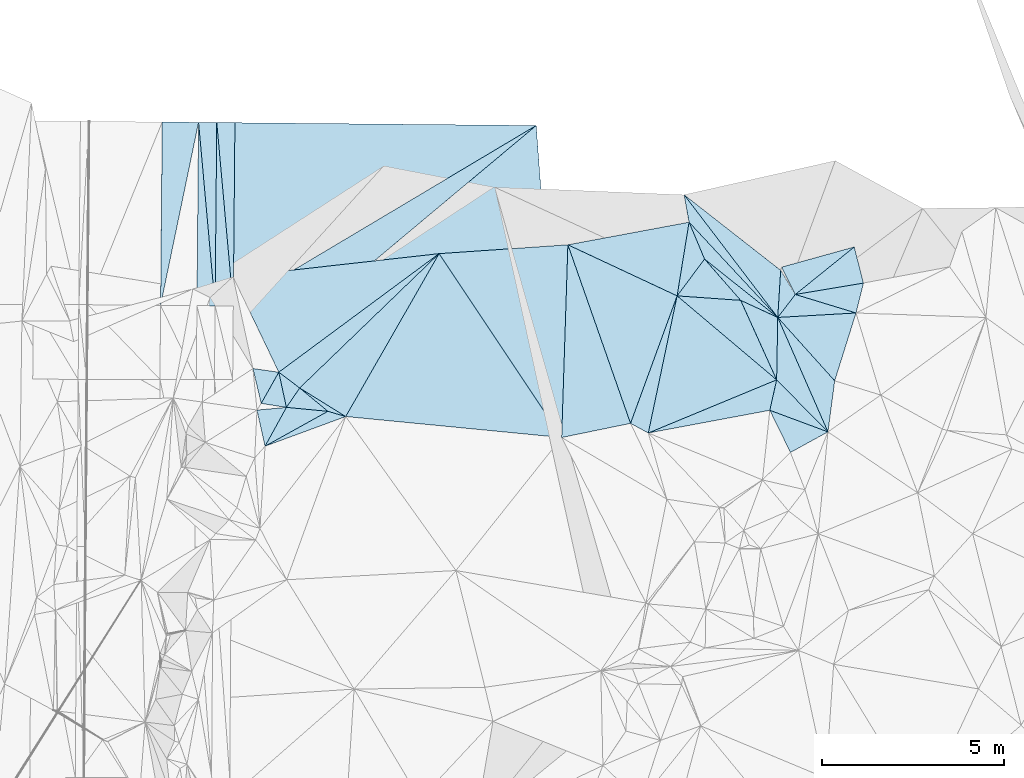
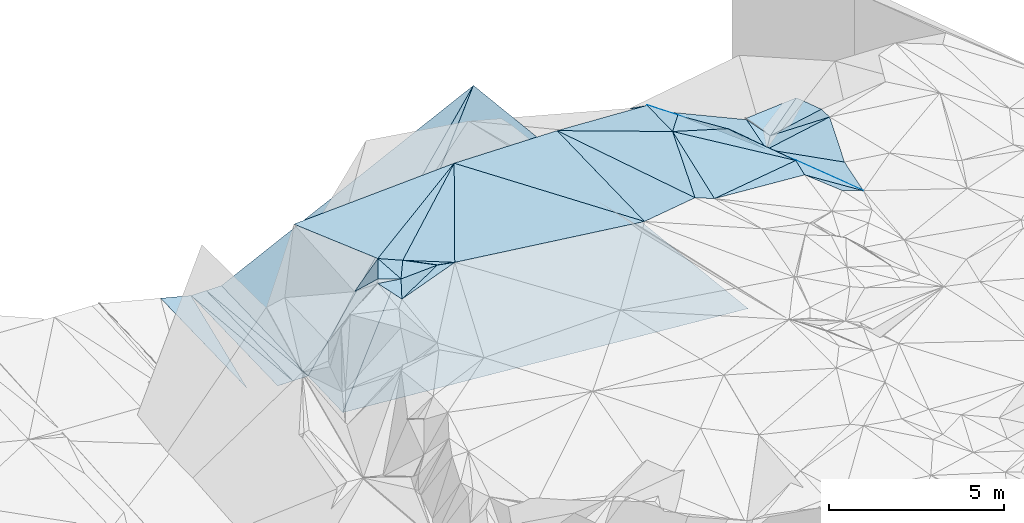
# One storey, part 162 of 275: 45 plates.
"""IFC2X3 building model written with IfcOpenShell, lengths in millimetres."""

from ifc_helpers import new_model, si_unit, frame, origin_with_axes, place, context, subcontext, project, spatial, polyline, outline, extrude, material, type_object, element, save


model = new_model("IFC2X3")

# Units and contexts
model_context = context("Model", 3, precision=1e-05, world=origin_with_axes())
body_context = subcontext(model_context, "Body", "Model", "MODEL_VIEW")
ifc_project = project(units=[si_unit("LENGTHUNIT", "METRE", prefix="MILLI"), si_unit("AREAUNIT", "SQUARE_METRE"), si_unit("VOLUMEUNIT", "CUBIC_METRE"), si_unit("MASSUNIT", "GRAM", prefix="KILO"), si_unit("TIMEUNIT", "SECOND"), si_unit("PLANEANGLEUNIT", "RADIAN"), si_unit("SOLIDANGLEUNIT", "STERADIAN"), si_unit("THERMODYNAMICTEMPERATUREUNIT", "DEGREE_CELSIUS"), si_unit("LUMINOUSINTENSITYUNIT", "LUMEN")], contexts=[model_context])

# Site, building, storey
site_placement = place(None, origin_with_axes())
site = spatial("IfcSite", under=ifc_project, at=site_placement, CompositionType="ELEMENT")
building_placement = place(site_placement, origin_with_axes())
building = spatial("IfcBuilding", under=site, at=building_placement, Name="Undefined", CompositionType="ELEMENT")
storey_placement = place(building_placement, origin_with_axes())
storey = spatial("IfcBuildingStorey", under=building, at=storey_placement, Name="Undefined", CompositionType="ELEMENT", Elevation=0.0)

# Plates
ifc_material = material()
plate_type_1 = type_object("IfcPlateType", PredefinedType="NOTDEFINED")
plate_1_placement = place(storey_placement, frame((-46244.4376290686, 136333.243297459, 47419.5004117184), z_axis=(-0.0386080624922437, -0.0113269272799957, -0.999190231251782), x_axis=(-0.496956072066929, -0.867289861432958, 0.0290337509015122)))
element("IfcPlate", 1, at=plate_1_placement, inside=storey, type_object=plate_type_1, material=ifc_material, Name="00", context=body_context, shape_type="SweptSolid", body=[
    extrude(outline(polyline([(0.0, 0.0), (5166.40087890625, -3.6452547647059e-08), (5115.41796875, 1489.12744140625), (0.0, 0.0)])), frame((-8.85201319254618e-08, 2.18876761149539e-07, -0.5000001331573), z_axis=(0.0, 0.0, 1.0), x_axis=(1.0, 0.0, 0.0)), (0.0, 0.0, 1.0), 1.0),
])
plate_type_2 = type_object("IfcPlateType", PredefinedType="NOTDEFINED")
plate_2_placement = place(storey_placement, frame((-34775.135239956, 134701.446609209, 46009.5065014424), z_axis=(0.136923855636951, 0.0839839458284691, -0.987014971821903), x_axis=(-0.297121809859925, -0.947039181106434, -0.121800737086512)))
element("IfcPlate", 2, at=plate_2_placement, inside=storey, type_object=plate_type_2, material=ifc_material, Name="00", context=body_context, shape_type="SweptSolid", body=[
    extrude(outline(polyline([(0.0, 0.0), (1970.43139648438, -1.49884726852179e-08), (793.288208007813, 2028.06872558594), (0.0, 0.0)])), frame((-8.85201319254618e-08, 2.18876761149539e-07, -0.5000001331573), z_axis=(0.0, 0.0, 1.0), x_axis=(1.0, 0.0, 0.0)), (0.0, 0.0, 1.0), 1.0),
])
plate_type_3 = type_object("IfcPlateType", PredefinedType="NOTDEFINED")
plate_3_placement = place(storey_placement, frame((-51859.148715105, 139935.952428998, 42920.9400722142), z_axis=(0.000157570782075281, 0.0167925502270225, -0.999858982771231), x_axis=(-0.00895969890029244, -0.999818838227281, -0.0167932879885519)))
element("IfcPlate", 3, at=plate_3_placement, inside=storey, type_object=plate_type_3, material=ifc_material, Name="00_PR", context=body_context, shape_type="SweptSolid", body=[
    extrude(outline(polyline([(0.0, 0.0), (5042.31201171875, -1.64654920808971e-08), (-0.210982531309128, 500.000518798828), (0.0, 0.0)])), frame((-8.85201319254618e-08, 2.18876761149539e-07, -0.5000001331573), z_axis=(0.0, 0.0, 1.0), x_axis=(1.0, 0.0, 0.0)), (0.0, 0.0, 1.0), 1.0),
])
plate_4_placement = place(storey_placement, frame((-52359.1272768287, 139940.64391924, 42920.9400725235), z_axis=(0.000157572110152841, 0.0167911431673699, -0.999859006401484), x_axis=(-0.0089596369135972, -0.99981886241407, -0.0167918809968538)))
element("IfcPlate", 4, at=plate_4_placement, inside=storey, type_object=plate_type_3, material=ifc_material, Name="00_PR", context=body_context, shape_type="SweptSolid", body=[
    extrude(outline(polyline([(0.0, 0.0), (5042.734375, -1.67347025126219e-10), (-0.211426600813866, 499.999603271484), (0.0, 0.0)])), frame((-8.85201319254618e-08, 2.18876761149539e-07, -0.5000001331573), z_axis=(0.0, 0.0, 1.0), x_axis=(1.0, 0.0, 0.0)), (0.0, 0.0, 1.0), 1.0),
])
plate_5_placement = place(storey_placement, frame((-52404.3083522022, 134898.822822037, 42836.2630724889), z_axis=(0.000143369686278446, 0.0167912704451332, -0.999859006401388), x_axis=(0.00895963691508711, 0.999818862413953, 0.0167918810030018)))
element("IfcPlate", 5, at=plate_5_placement, inside=storey, type_object=plate_type_3, material=ifc_material, Name="00_PR", context=body_context, shape_type="SweptSolid", body=[
    extrude(outline(polyline([(0.0, 0.0), (5042.734375, -1.67347025126219e-10), (0.211420238018036, 500.000213623047), (0.0, 0.0)])), frame((-8.85201319254618e-08, 2.18876761149539e-07, -0.5000001331573), z_axis=(0.0, 0.0, 1.0), x_axis=(1.0, 0.0, 0.0)), (0.0, 0.0, 1.0), 1.0),
])
plate_6_placement = place(storey_placement, frame((-52904.2903879843, 134903.091827769, 42836.2630724597), z_axis=(0.000143357042514906, 0.0167898625020091, -0.999859030046697), x_axis=(0.00895975488252964, 0.999818885003081, 0.0167904730022705)))
element("IfcPlate", 6, at=plate_6_placement, inside=storey, type_object=plate_type_3, material=ifc_material, Name="00_PR", context=body_context, shape_type="SweptSolid", body=[
    extrude(outline(polyline([(0.0, 0.0), (5043.1572265625, 7.13480403646827e-08), (0.211480021476746, 500.000213623047), (0.0, 0.0)])), frame((-8.85201319254618e-08, 2.18876761149539e-07, -0.5000001331573), z_axis=(0.0, 0.0, 1.0), x_axis=(1.0, 0.0, 0.0)), (0.0, 0.0, 1.0), 1.0),
])
plate_type_4 = type_object("IfcPlateType", PredefinedType="NOTDEFINED")
plate_7_placement = place(storey_placement, frame((-35546.6257856612, 131430.146122365, 45684.5732970128), z_axis=(-0.479207646267053, -0.205008901835523, -0.853423331018894), x_axis=(-0.749342379000932, -0.410710457073522, 0.519425566836753)))
element("IfcPlate", 7, at=plate_7_placement, inside=storey, type_object=plate_type_4, material=ifc_material, Name="00", context=body_context, shape_type="SweptSolid", body=[
    extrude(outline(polyline([(0.0, 0.0), (1376.52062988281, -5.96628524363041e-09), (1346.15417480469, 1291.23120117188), (0.0, 0.0)])), frame((-8.85201319254618e-08, 2.18876761149539e-07, -0.5000001331573), z_axis=(0.0, 0.0, 1.0), x_axis=(1.0, 0.0, 0.0)), (0.0, 0.0, 1.0), 1.0),
])
plate_type_5 = type_object("IfcPlateType", PredefinedType="NOTDEFINED")
plate_8_placement = place(storey_placement, frame((-53904.3751885728, 134911.631997105, 43086.2779941907), z_axis=(-0.242341374753198, 0.0184589668019858, -0.970015424942992), x_axis=(0.00895979286156584, 0.999818931781241, 0.0167876670117159)))
element("IfcPlate", 8, at=plate_8_placement, inside=storey, type_object=plate_type_5, material=ifc_material, Name="00_PR", context=body_context, shape_type="SweptSolid", body=[
    extrude(outline(polyline([(0.0, 0.0), (5044.00048828125, 3.51283233612776e-08), (5039.38232421875, 1030.76586914063), (0.0, 0.0)])), frame((-8.85201319254618e-08, 2.18876761149539e-07, -0.5000001331573), z_axis=(0.0, 0.0, 1.0), x_axis=(1.0, 0.0, 0.0)), (0.0, 0.0, 1.0), 1.0),
])
plate_type_6 = type_object("IfcPlateType", PredefinedType="NOTDEFINED")
plate_9_placement = place(storey_placement, frame((-36927.320697476, 134578.794818653, 45700.5098295591), z_axis=(0.105386591877929, 0.166703633182448, -0.980358895984591), x_axis=(-0.605194913293175, 0.793012335236135, 0.0697893479508037)))
element("IfcPlate", 9, at=plate_9_placement, inside=storey, type_object=plate_type_6, material=ifc_material, Name="00", context=body_context, shape_type="SweptSolid", body=[
    extrude(outline(polyline([(0.0, 0.0), (4255.66357421875, 5.42058842256665e-09), (994.169494628906, 865.318481445313), (0.0, 0.0)])), frame((-8.85201319254618e-08, 2.18876761149539e-07, -0.5000001331573), z_axis=(0.0, 0.0, 1.0), x_axis=(1.0, 0.0, 0.0)), (0.0, 0.0, 1.0), 1.0),
])
plate_type_7 = type_object("IfcPlateType", PredefinedType="NOTDEFINED")
plate_10_placement = place(storey_placement, frame((-36819.7772892426, 135962.541853178, 45909.5272244317), z_axis=(-0.214774493960128, 0.24457908634839, -0.945543752168644), x_axis=(0.952909028036218, 0.264701228696749, -0.147978524838915)))
element("IfcPlate", 10, at=plate_10_placement, inside=storey, type_object=plate_type_7, material=ifc_material, Name="00", context=body_context, shape_type="SweptSolid", body=[
    extrude(outline(polyline([(0.0, 0.0), (2094.89868164063, -1.06520019471645e-08), (200.868911743164, 863.279602050781), (0.0, 0.0)])), frame((-8.85201319254618e-08, 2.18876761149539e-07, -0.5000001331573), z_axis=(0.0, 0.0, 1.0), x_axis=(1.0, 0.0, 0.0)), (0.0, 0.0, 1.0), 1.0),
])
plate_type_8 = type_object("IfcPlateType", PredefinedType="NOTDEFINED")
plate_11_placement = place(storey_placement, frame((-48811.8595582103, 131852.560195411, 47569.5073191274), z_axis=(0.0662670248498581, 0.156985275425586, -0.985375210119019), x_axis=(-0.959197434103375, 0.282059013979248, -0.019570259133592)))
element("IfcPlate", 11, at=plate_11_placement, inside=storey, type_object=plate_type_8, material=ifc_material, Name="00", context=body_context, shape_type="SweptSolid", body=[
    extrude(outline(polyline([(0.0, 0.0), (510.979461669922, -1.20780896395445e-09), (1434.69567871094, 402.179534912109), (0.0, 0.0)])), frame((-8.85201319254618e-08, 2.18876761149539e-07, -0.5000001331573), z_axis=(0.0, 0.0, 1.0), x_axis=(1.0, 0.0, 0.0)), (0.0, 0.0, 1.0), 1.0),
])
plate_type_9 = type_object("IfcPlateType", PredefinedType="NOTDEFINED")
plate_12_placement = place(storey_placement, frame((-43571.5378030222, 139858.291037658, 47064.8685067219), z_axis=(0.445842561543699, 0.0147067022785573, -0.894990571583993), x_axis=(0.0742029751051019, -0.997030762069267, 0.0205810100123245)))
element("IfcPlate", 12, at=plate_12_placement, inside=storey, type_object=plate_type_9, material=ifc_material, Name="00_PR", context=body_context, shape_type="SweptSolid", body=[
    extrude(outline(polyline([(0.0, 0.0), (13973.9501953125, 5.7756551541388e-08), (6256.111328125, 9880.494140625), (0.0, 0.0)])), frame((-8.85201319254618e-08, 2.18876761149539e-07, -0.5000001331573), z_axis=(0.0, 0.0, 1.0), x_axis=(1.0, 0.0, 0.0)), (0.0, 0.0, 1.0), 1.0),
])
plate_type_10 = type_object("IfcPlateType", PredefinedType="NOTDEFINED")
plate_13_placement = place(storey_placement, frame((-51904.1027485191, 134894.550920529, 42836.3158399127), z_axis=(0.447284742987901, 0.0110130957555869, -0.89432380624253), x_axis=(0.00895969891887308, 0.999818838227141, 0.0167932879869457)))
element("IfcPlate", 13, at=plate_13_placement, inside=storey, type_object=plate_type_10, material=ifc_material, Name="00_PR", context=body_context, shape_type="SweptSolid", body=[
    extrude(outline(polyline([(0.0, 0.0), (5042.31201171875, -1.64654920808971e-08), (5108.5078125, 9265.751953125), (0.0, 0.0)])), frame((-8.85201319254618e-08, 2.18876761149539e-07, -0.5000001331573), z_axis=(0.0, 0.0, 1.0), x_axis=(1.0, 0.0, 0.0)), (0.0, 0.0, 1.0), 1.0),
])
plate_type_11 = type_object("IfcPlateType", PredefinedType="NOTDEFINED")
plate_14_placement = place(storey_placement, frame((-51921.0175795062, 132873.921232352, 42790.7782281115), z_axis=(0.444661033057132, 0.016460080166718, -0.895547671227763), x_axis=(0.00836798990768207, 0.999711157382434, 0.0225295039887469)))
element("IfcPlate", 14, at=plate_14_placement, inside=storey, type_object=plate_type_11, material=ifc_material, Name="00_PR", context=body_context, shape_type="SweptSolid", body=[
    extrude(outline(polyline([(0.0, 0.0), (2021.21618652344, -1.95432221516967e-08), (7148.5146484375, 9255.3671875), (0.0, 0.0)])), frame((-8.85201319254618e-08, 2.18876761149539e-07, -0.5000001331573), z_axis=(0.0, 0.0, 1.0), x_axis=(1.0, 0.0, 0.0)), (0.0, 0.0, 1.0), 1.0),
])
plate_type_12 = type_object("IfcPlateType", PredefinedType="NOTDEFINED")
plate_15_placement = place(storey_placement, frame((-38940.6285945872, 136183.60823865, 46629.7298342377), z_axis=(-0.662775754034027, -0.518412759155638, -0.54034850884338), x_axis=(0.735436203202143, -0.586455286024265, -0.339416835931592)))
element("IfcPlate", 15, at=plate_15_placement, inside=storey, type_object=plate_type_12, material=ifc_material, Name="00", context=body_context, shape_type="SweptSolid", body=[
    extrude(outline(polyline([(0.0, 0.0), (2737.04760742188, 7.13043846189976e-09), (1440.69482421875, 466.260223388672), (0.0, 0.0)])), frame((-8.85201319254618e-08, 2.18876761149539e-07, -0.5000001331573), z_axis=(0.0, 0.0, 1.0), x_axis=(1.0, 0.0, 0.0)), (0.0, 0.0, 1.0), 1.0),
])
plate_type_13 = type_object("IfcPlateType", PredefinedType="NOTDEFINED")
plate_16_placement = place(storey_placement, frame((-51363.5545295183, 133173.186690399, 46639.7149588364), z_axis=(0.721402230275788, -0.393155562048837, -0.570094313410669), x_axis=(0.589417075987927, -0.0835808220431005, 0.803493470241322)))
element("IfcPlate", 16, at=plate_16_placement, inside=storey, type_object=plate_type_13, material=ifc_material, Name="00", context=body_context, shape_type="SweptSolid", body=[
    extrude(outline(polyline([(0.0, 0.0), (1207.22827148438, 5.2677933126688e-09), (977.694152832031, 959.121520996094), (0.0, 0.0)])), frame((-8.85201319254618e-08, 2.18876761149539e-07, -0.5000001331573), z_axis=(0.0, 0.0, 1.0), x_axis=(1.0, 0.0, 0.0)), (0.0, 0.0, 1.0), 1.0),
])
plate_type_14 = type_object("IfcPlateType", PredefinedType="NOTDEFINED")
plate_17_placement = place(storey_placement, frame((-39503.2274468541, 137953.263057063, 45997.7350435904), z_axis=(-0.695998020210356, -0.484520779905398, -0.529930532903257), x_axis=(0.605194913294823, -0.793012335234618, -0.0697893479537419)))
element("IfcPlate", 17, at=plate_17_placement, inside=storey, type_object=plate_type_14, material=ifc_material, Name="00", context=body_context, shape_type="SweptSolid", body=[
    extrude(outline(polyline([(0.0, 0.0), (4255.66357421875, 5.42058842256665e-09), (645.740173339844, 659.12109375), (0.0, 0.0)])), frame((-8.85201319254618e-08, 2.18876761149539e-07, -0.5000001331573), z_axis=(0.0, 0.0, 1.0), x_axis=(1.0, 0.0, 0.0)), (0.0, 0.0, 1.0), 1.0),
])
plate_type_15 = type_object("IfcPlateType", PredefinedType="NOTDEFINED")
plate_18_placement = place(storey_placement, frame((-50443.1756033586, 132104.519434518, 47409.5187827994), z_axis=(-0.226321564641346, 0.149913753549797, -0.962447097701948), x_axis=(-0.956892968536815, 0.150432057028558, 0.24844726398767)))
element("IfcPlate", 18, at=plate_18_placement, inside=storey, type_object=plate_type_15, material=ifc_material, Name="00", context=body_context, shape_type="SweptSolid", body=[
    extrude(outline(polyline([(0.0, 0.0), (724.499816894531, -2.66300048679113e-09), (395.583251953125, 929.738586425781), (0.0, 0.0)])), frame((-8.85201319254618e-08, 2.18876761149539e-07, -0.5000001331573), z_axis=(0.0, 0.0, 1.0), x_axis=(1.0, 0.0, 0.0)), (0.0, 0.0, 1.0), 1.0),
])
plate_type_16 = type_object("IfcPlateType", PredefinedType="NOTDEFINED")
plate_19_placement = place(storey_placement, frame((-36927.560229879, 134578.803524072, 45700.5454557012), z_axis=(-0.373670903157089, 0.18411071841037, -0.909105769149104), x_axis=(0.0615558998279532, 0.982864640865711, 0.173746853014054)))
element("IfcPlate", 19, at=plate_19_placement, inside=storey, type_object=plate_type_16, material=ifc_material, Name="00", context=body_context, shape_type="SweptSolid", body=[
    extrude(outline(polyline([(0.0, 0.0), (1318.00952148438, 1.48866092786193e-08), (638.242004394531, 480.433288574219), (0.0, 0.0)])), frame((-8.85201319254618e-08, 2.18876761149539e-07, -0.5000001331573), z_axis=(0.0, 0.0, 1.0), x_axis=(1.0, 0.0, 0.0)), (0.0, 0.0, 1.0), 1.0),
])
plate_type_17 = type_object("IfcPlateType", PredefinedType="NOTDEFINED")
plate_20_placement = place(storey_placement, frame((-34775.1281991288, 134701.292649732, 46009.518591383), z_axis=(0.151006235386335, -0.223932998288147, -0.96283494387778), x_axis=(-0.988277345270998, -0.0563407521671171, -0.141892947214975)))
element("IfcPlate", 20, at=plate_20_placement, inside=storey, type_object=plate_type_17, material=ifc_material, Name="00", context=body_context, shape_type="SweptSolid", body=[
    extrude(outline(polyline([(0.0, 0.0), (2177.69799804688, -3.18686943501234e-09), (1673.92346191406, 619.984008789063), (0.0, 0.0)])), frame((-8.85201319254618e-08, 2.18876761149539e-07, -0.5000001331573), z_axis=(0.0, 0.0, 1.0), x_axis=(1.0, 0.0, 0.0)), (0.0, 0.0, 1.0), 1.0),
])
plate_type_18 = type_object("IfcPlateType", PredefinedType="NOTDEFINED")
plate_21_placement = place(storey_placement, frame((-35546.3379275118, 131430.272309615, 45684.5029074077), z_axis=(0.09651605629017, 0.047386515002329, -0.994202780661031), x_axis=(-0.401677258215196, 0.915769470116412, 0.004653797957486)))
element("IfcPlate", 21, at=plate_21_placement, inside=storey, type_object=plate_type_18, material=ifc_material, Name="00", context=body_context, shape_type="SweptSolid", body=[
    extrude(outline(polyline([(0.0, 0.0), (3438.0517578125, -4.01887518819422e-08), (1212.52392578125, 738.752136230469), (0.0, 0.0)])), frame((-8.85201319254618e-08, 2.18876761149539e-07, -0.5000001331573), z_axis=(0.0, 0.0, 1.0), x_axis=(1.0, 0.0, 0.0)), (0.0, 0.0, 1.0), 1.0),
])
plate_type_19 = type_object("IfcPlateType", PredefinedType="NOTDEFINED")
plate_22_placement = place(storey_placement, frame((-37145.4156615234, 132024.532530279, 46439.5466420665), z_axis=(-0.421298830994619, 0.0185146971718052, -0.906732871903961), x_axis=(0.217747407813242, 0.972612087714473, -0.0813129339177258)))
element("IfcPlate", 22, at=plate_22_placement, inside=storey, type_object=plate_type_19, material=ifc_material, Name="00", context=body_context, shape_type="SweptSolid", body=[
    extrude(outline(polyline([(0.0, 0.0), (860.871643066406, 3.92901711165905e-09), (-168.468780517578, 1857.69409179688), (0.0, 0.0)])), frame((-8.85201319254618e-08, 2.18876761149539e-07, -0.5000001331573), z_axis=(0.0, 0.0, 1.0), x_axis=(1.0, 0.0, 0.0)), (0.0, 0.0, 1.0), 1.0),
])
plate_type_20 = type_object("IfcPlateType", PredefinedType="NOTDEFINED")
plate_23_placement = place(storey_placement, frame((-40976.8369638917, 131664.480999141, 47199.5003634887), z_axis=(-0.0332726983756225, -0.0177759419078779, -0.999288218399523), x_axis=(-0.978897722071505, -0.201124025120607, 0.0361714838305441)))
element("IfcPlate", 23, at=plate_23_placement, inside=storey, type_object=plate_type_20, material=ifc_material, Name="00", context=body_context, shape_type="SweptSolid", body=[
    extrude(outline(polyline([(0.0, 0.0), (1935.22607421875, 3.23052518069744e-09), (698.057983398438, 5159.24560546875), (0.0, 0.0)])), frame((-8.85201319254618e-08, 2.18876761149539e-07, -0.5000001331573), z_axis=(0.0, 0.0, 1.0), x_axis=(1.0, 0.0, 0.0)), (0.0, 0.0, 1.0), 1.0),
])
plate_type_21 = type_object("IfcPlateType", PredefinedType="NOTDEFINED")
plate_24_placement = place(storey_placement, frame((-42871.234157196, 131275.267279928, 47269.5006588532), z_axis=(-0.0508507838858803, -0.00429535080624726, -0.998697024997893), x_axis=(-0.994058012040613, 0.0965852579093277, 0.0501991698382983)))
element("IfcPlate", 24, at=plate_24_placement, inside=storey, type_object=plate_type_21, material=ifc_material, Name="00", context=body_context, shape_type="SweptSolid", body=[
    extrude(outline(polyline([(0.0, 0.0), (5976.1943359375, -1.14378053694963e-08), (3849.22216796875, 4708.25732421875), (0.0, 0.0)])), frame((-8.85201319254618e-08, 2.18876761149539e-07, -0.5000001331573), z_axis=(0.0, 0.0, 1.0), x_axis=(1.0, 0.0, 0.0)), (0.0, 0.0, 1.0), 1.0),
])
plate_type_22 = type_object("IfcPlateType", PredefinedType="NOTDEFINED")
plate_25_placement = place(storey_placement, frame((-39367.0847781786, 137197.852595581, 46509.6392005573), z_axis=(-0.603510851704187, -0.339181763988995, -0.721616506776695), x_axis=(0.664761113161768, -0.713785781988604, -0.220459791932327)))
element("IfcPlate", 25, at=plate_25_placement, inside=storey, type_object=plate_type_22, material=ifc_material, Name="00", context=body_context, shape_type="SweptSolid", body=[
    extrude(outline(polyline([(0.0, 0.0), (3669.60327148438, -1.77242327481508e-08), (980.945251464844, 512.392822265625), (0.0, 0.0)])), frame((-8.85201319254618e-08, 2.18876761149539e-07, -0.5000001331573), z_axis=(0.0, 0.0, 1.0), x_axis=(1.0, 0.0, 0.0)), (0.0, 0.0, 1.0), 1.0),
])
plate_type_23 = type_object("IfcPlateType", PredefinedType="NOTDEFINED")
plate_26_placement = place(storey_placement, frame((-36927.6881325758, 134578.575264685, 45700.6361639091), z_axis=(-0.629491463325286, -0.272411224926309, -0.727689921693807), x_axis=(0.401677258124083, -0.915769470156276, -0.00465379797722956)))
element("IfcPlate", 26, at=plate_26_placement, inside=storey, type_object=plate_type_23, material=ifc_material, Name="00", context=body_context, shape_type="SweptSolid", body=[
    extrude(outline(polyline([(0.0, 0.0), (3438.0517578125, -4.01887518819422e-08), (1556.96313476563, 985.9384765625), (0.0, 0.0)])), frame((-8.85201319254618e-08, 2.18876761149539e-07, -0.5000001331573), z_axis=(0.0, 0.0, 1.0), x_axis=(1.0, 0.0, 0.0)), (0.0, 0.0, 1.0), 1.0),
])
plate_type_24 = type_object("IfcPlateType", PredefinedType="NOTDEFINED")
plate_27_placement = place(storey_placement, frame((-40488.0446903618, 131399.521492747, 47159.5108527394), z_axis=(-0.203966375717843, -0.0361256032712806, -0.978311125544841), x_axis=(0.904742868791664, 0.37476322498851, -0.202466951789277)))
element("IfcPlate", 27, at=plate_27_placement, inside=storey, type_object=plate_type_24, material=ifc_material, Name="00", context=body_context, shape_type="SweptSolid", body=[
    extrude(outline(polyline([(0.0, 0.0), (3901.87133789063, 1.158332452178e-08), (3404.31518554688, 702.522521972656), (0.0, 0.0)])), frame((-8.85201319254618e-08, 2.18876761149539e-07, -0.5000001331573), z_axis=(0.0, 0.0, 1.0), x_axis=(1.0, 0.0, 0.0)), (0.0, 0.0, 1.0), 1.0),
])
plate_type_25 = type_object("IfcPlateType", PredefinedType="NOTDEFINED")
plate_28_placement = place(storey_placement, frame((-50443.1640731628, 132104.431703615, 47409.5106106708), z_axis=(-0.203262075228054, -0.0255464828312658, -0.978791043067384), x_axis=(-0.478312380962079, -0.869670319969687, 0.122027868875143)))
element("IfcPlate", 28, at=plate_28_placement, inside=storey, type_object=plate_type_25, material=ifc_material, Name="00", context=body_context, shape_type="SweptSolid", body=[
    extrude(outline(polyline([(0.0, 0.0), (1229.22741699219, -1.12049747258425e-09), (471.841094970703, 683.202758789063), (0.0, 0.0)])), frame((-8.85201319254618e-08, 2.18876761149539e-07, -0.5000001331573), z_axis=(0.0, 0.0, 1.0), x_axis=(1.0, 0.0, 0.0)), (0.0, 0.0, 1.0), 1.0),
])
plate_type_26 = type_object("IfcPlateType", PredefinedType="NOTDEFINED")
plate_29_placement = place(storey_placement, frame((-50652.2650957086, 133072.60010639, 47609.5223792158), z_axis=(0.178402508741945, 0.235929803739297, -0.955253721574597), x_axis=(0.797632397849618, -0.603143894854842, 9.48093192619869e-11)))
element("IfcPlate", 29, at=plate_29_placement, inside=storey, type_object=plate_type_26, material=ifc_material, Name="00", context=body_context, shape_type="SweptSolid", body=[
    extrude(outline(polyline([(0.0, 0.0), (720.694091796875, 5.28234522789717e-09), (750.803955078125, 676.160766601563), (0.0, 0.0)])), frame((-8.85201319254618e-08, 2.18876761149539e-07, -0.5000001331573), z_axis=(0.0, 0.0, 1.0), x_axis=(1.0, 0.0, 0.0)), (0.0, 0.0, 1.0), 1.0),
])
plate_type_27 = type_object("IfcPlateType", PredefinedType="NOTDEFINED")
plate_30_placement = place(storey_placement, frame((-40488.0494930242, 131399.533495662, 47159.511582866), z_axis=(-0.21358656415154, -0.0121109366475225, -0.976849069625119), x_axis=(0.205195008071381, 0.977061096373279, -0.0569791419418659)))
element("IfcPlate", 30, at=plate_30_placement, inside=storey, type_object=plate_type_27, material=ifc_material, Name="00", context=body_context, shape_type="SweptSolid", body=[
    extrude(outline(polyline([(0.0, 0.0), (3861.06201171875, 1.91794242709875e-08), (2198.12573242188, 3223.79321289063), (0.0, 0.0)])), frame((-8.85201319254618e-08, 2.18876761149539e-07, -0.5000001331573), z_axis=(0.0, 0.0, 1.0), x_axis=(1.0, 0.0, 0.0)), (0.0, 0.0, 1.0), 1.0),
])
plate_type_28 = type_object("IfcPlateType", PredefinedType="NOTDEFINED")
plate_31_placement = place(storey_placement, frame((-39695.7226667714, 135172.014694838, 46939.5029157405), z_axis=(-0.101242421336579, -0.0367155291046147, -0.994184058434088), x_axis=(-0.205195008059359, -0.977061096375732, 0.0569791419430952)))
element("IfcPlate", 31, at=plate_31_placement, inside=storey, type_object=plate_type_28, material=ifc_material, Name="00", context=body_context, shape_type="SweptSolid", body=[
    extrude(outline(polyline([(0.0, 0.0), (3861.06201171875, 1.91794242709875e-08), (3704.78369140625, 535.142150878906), (0.0, 0.0)])), frame((-8.85201319254618e-08, 2.18876761149539e-07, -0.5000001331573), z_axis=(0.0, 0.0, 1.0), x_axis=(1.0, 0.0, 0.0)), (0.0, 0.0, 1.0), 1.0),
])
plate_type_29 = type_object("IfcPlateType", PredefinedType="NOTDEFINED")
plate_32_placement = place(storey_placement, frame((-50442.987587154, 132104.572251597, 47409.5224388813), z_axis=(0.149712236050691, 0.255548973689906, -0.955134005479199), x_axis=(0.540101141783173, 0.788018766806466, 0.295494805039495)))
element("IfcPlate", 32, at=plate_32_placement, inside=storey, type_object=plate_type_29, material=ifc_material, Name="00", context=body_context, shape_type="SweptSolid", body=[
    extrude(outline(polyline([(0.0, 0.0), (676.830871582031, 6.46105036139488e-09), (575.623901367188, 1002.37573242188), (0.0, 0.0)])), frame((-8.85201319254618e-08, 2.18876761149539e-07, -0.5000001331573), z_axis=(0.0, 0.0, 1.0), x_axis=(1.0, 0.0, 0.0)), (0.0, 0.0, 1.0), 1.0),
])
plate_type_30 = type_object("IfcPlateType", PredefinedType="NOTDEFINED")
plate_33_placement = place(storey_placement, frame((-36958.0860349426, 132861.687364764, 46369.6510305635), z_axis=(-0.667217446647532, -0.260156756633482, -0.6979536810327), x_axis=(-0.411348049090433, 0.909872266123339, 0.054085504981224)))
element("IfcPlate", 33, at=plate_33_placement, inside=storey, type_object=plate_type_30, material=ifc_material, Name="00", context=body_context, shape_type="SweptSolid", body=[
    extrude(outline(polyline([(0.0, 0.0), (2403.6015625, -2.47018761001527e-09), (1513.47473144531, 1051.47668457031), (0.0, 0.0)])), frame((-8.85201319254618e-08, 2.18876761149539e-07, -0.5000001331573), z_axis=(0.0, 0.0, 1.0), x_axis=(1.0, 0.0, 0.0)), (0.0, 0.0, 1.0), 1.0),
])
plate_type_31 = type_object("IfcPlateType", PredefinedType="NOTDEFINED")
plate_34_placement = place(storey_placement, frame((-39695.7956349918, 135172.005934323, 46939.5162814112), z_axis=(-0.247177272943977, -0.0542392738849255, -0.967451030754743), x_axis=(0.967533320872607, -0.0681704429513634, -0.243376382808687)))
element("IfcPlate", 34, at=plate_34_placement, inside=storey, type_object=plate_type_31, material=ifc_material, Name="00", context=body_context, shape_type="SweptSolid", body=[
    extrude(outline(polyline([(0.0, 0.0), (1807.89929199219, -1.94995664060116e-09), (2945.24145507813, 2117.4873046875), (0.0, 0.0)])), frame((-8.85201319254618e-08, 2.18876761149539e-07, -0.5000001331573), z_axis=(0.0, 0.0, 1.0), x_axis=(1.0, 0.0, 0.0)), (0.0, 0.0, 1.0), 1.0),
])
plate_type_32 = type_object("IfcPlateType", PredefinedType="NOTDEFINED")
plate_35_placement = place(storey_placement, frame((-42700.4218907634, 136577.062304305, 47169.5026303395), z_axis=(-0.0944873173086888, -0.039225039556415, -0.994753006097295), x_axis=(0.903683237033058, -0.42257729695776, -0.0691739488631857)))
element("IfcPlate", 35, at=plate_35_placement, inside=storey, type_object=plate_type_32, material=ifc_material, Name="00", context=body_context, shape_type="SweptSolid", body=[
    extrude(outline(polyline([(0.0, 0.0), (3324.951171875, 7.53789208829403e-09), (3631.421875, 3730.6669921875), (0.0, 0.0)])), frame((-8.85201319254618e-08, 2.18876761149539e-07, -0.5000001331573), z_axis=(0.0, 0.0, 1.0), x_axis=(1.0, 0.0, 0.0)), (0.0, 0.0, 1.0), 1.0),
])
plate_type_33 = type_object("IfcPlateType", PredefinedType="NOTDEFINED")
plate_36_placement = place(storey_placement, frame((-46244.4529223303, 136333.240679953, 47419.5012748644), z_axis=(-0.0692210277528971, -0.0165832048135222, -0.997463506417626), x_axis=(0.995180287774011, 0.068469174022448, -0.0702009047998696)))
element("IfcPlate", 36, at=plate_36_placement, inside=storey, type_object=plate_type_33, material=ifc_material, Name="00", context=body_context, shape_type="SweptSolid", body=[
    extrude(outline(polyline([(0.0, 0.0), (3561.20776367188, 1.36788003146648e-08), (3021.16625976563, 5277.94970703125), (0.0, 0.0)])), frame((-8.85201319254618e-08, 2.18876761149539e-07, -0.5000001331573), z_axis=(0.0, 0.0, 1.0), x_axis=(1.0, 0.0, 0.0)), (0.0, 0.0, 1.0), 1.0),
])
plate_type_34 = type_object("IfcPlateType", PredefinedType="NOTDEFINED")
plate_37_placement = place(storey_placement, frame((-51031.0104626958, 131035.409896202, 47559.5001944199), z_axis=(0.0133392182580824, -0.0239947598516419, -0.999623087346388), x_axis=(0.874021225159468, 0.485887742149093, 1.96948978773371e-10)))
element("IfcPlate", 37, at=plate_37_placement, inside=storey, type_object=plate_type_34, material=ifc_material, Name="00", context=body_context, shape_type="SweptSolid", body=[
    extrude(outline(polyline([(0.0, 0.0), (1978.20629882813, 6.05359673500061e-09), (2336.56127929688, 364.255035400391), (0.0, 0.0)])), frame((-8.85201319254618e-08, 2.18876761149539e-07, -0.5000001331573), z_axis=(0.0, 0.0, 1.0), x_axis=(1.0, 0.0, 0.0)), (0.0, 0.0, 1.0), 1.0),
])
plate_type_35 = type_object("IfcPlateType", PredefinedType="NOTDEFINED")
plate_38_placement = place(storey_placement, frame((-39366.8614011905, 137197.931902104, 46509.5144879613), z_axis=(-0.156458570502285, -0.180691586935284, -0.971015584904377), x_axis=(0.385364761700781, -0.916371637979195, 0.108429800085708)))
element("IfcPlate", 38, at=plate_38_placement, inside=storey, type_object=plate_type_35, material=ifc_material, Name="00", context=body_context, shape_type="SweptSolid", body=[
    extrude(outline(polyline([(0.0, 0.0), (1106.70678710938, 3.20142135024071e-09), (1776.44152832031, 1114.43054199219), (0.0, 0.0)])), frame((-8.85201319254618e-08, 2.18876761149539e-07, -0.5000001331573), z_axis=(0.0, 0.0, 1.0), x_axis=(1.0, 0.0, 0.0)), (0.0, 0.0, 1.0), 1.0),
])
plate_type_36 = type_object("IfcPlateType", PredefinedType="NOTDEFINED")
plate_39_placement = place(storey_placement, frame((-34570.4679802017, 135524.268746119, 45709.5367638655), z_axis=(0.100402305202733, -0.362675306323301, -0.926491230014228), x_axis=(-0.22752668410077, -0.91489037139844, 0.333477460024712)))
element("IfcPlate", 39, at=plate_39_placement, inside=storey, type_object=plate_type_36, material=ifc_material, Name="00", context=body_context, shape_type="SweptSolid", body=[
    extrude(outline(polyline([(0.0, 0.0), (899.611022949219, 1.78988557308912e-09), (686.852416992188, 1772.32434082031), (0.0, 0.0)])), frame((-8.85201319254618e-08, 2.18876761149539e-07, -0.5000001331573), z_axis=(0.0, 0.0, 1.0), x_axis=(1.0, 0.0, 0.0)), (0.0, 0.0, 1.0), 1.0),
])
plate_type_37 = type_object("IfcPlateType", PredefinedType="NOTDEFINED")
plate_40_placement = place(storey_placement, frame((-39695.7513604818, 135171.942902407, 46939.5146375017), z_axis=(-0.158610937973295, -0.180284134726794, -0.970742087848798), x_axis=(-0.903683237045706, 0.422577296933838, 0.0691739488440908)))
element("IfcPlate", 40, at=plate_40_placement, inside=storey, type_object=plate_type_37, material=ifc_material, Name="00", context=body_context, shape_type="SweptSolid", body=[
    extrude(outline(polyline([(0.0, 0.0), (3324.951171875, 7.53789208829403e-09), (529.180725097656, 2029.20373535156), (0.0, 0.0)])), frame((-8.85201319254618e-08, 2.18876761149539e-07, -0.5000001331573), z_axis=(0.0, 0.0, 1.0), x_axis=(1.0, 0.0, 0.0)), (0.0, 0.0, 1.0), 1.0),
])
plate_type_38 = type_object("IfcPlateType", PredefinedType="NOTDEFINED")
plate_41_placement = place(storey_placement, frame((-34823.3927855019, 136516.894099558, 45599.503141063), z_axis=(0.0584221451161902, -0.0952511128625913, -0.993737429333554), x_axis=(0.245514543018241, -0.96349330484655, 0.106786050973046)))
element("IfcPlate", 41, at=plate_41_placement, inside=storey, type_object=plate_type_38, material=ifc_material, Name="00", context=body_context, shape_type="SweptSolid", body=[
    extrude(outline(polyline([(0.0, 0.0), (1030.09704589844, 1.18550360639347e-08), (864.384521484375, 1893.52563476563), (0.0, 0.0)])), frame((-8.85201319254618e-08, 2.18876761149539e-07, -0.5000001331573), z_axis=(0.0, 0.0, 1.0), x_axis=(1.0, 0.0, 0.0)), (0.0, 0.0, 1.0), 1.0),
])
plate_type_39 = type_object("IfcPlateType", PredefinedType="NOTDEFINED")
plate_42_placement = place(storey_placement, frame((-46244.4394056312, 136333.248360151, 47419.5004529129), z_axis=(-0.0421791164883054, -0.00119846983236712, -0.999109346269129), x_axis=(-0.803456061764914, -0.594355924907621, 0.0346322297927812)))
element("IfcPlate", 42, at=plate_42_placement, inside=storey, type_object=plate_type_39, material=ifc_material, Name="00", context=body_context, shape_type="SweptSolid", body=[
    extrude(outline(polyline([(0.0, 0.0), (5486.21923828125, -4.26371116191149e-08), (4939.2119140625, 2859.9794921875), (0.0, 0.0)])), frame((-8.85201319254618e-08, 2.18876761149539e-07, -0.5000001331573), z_axis=(0.0, 0.0, 1.0), x_axis=(1.0, 0.0, 0.0)), (0.0, 0.0, 1.0), 1.0),
])
plate_type_40 = type_object("IfcPlateType", PredefinedType="NOTDEFINED")
plate_43_placement = place(storey_placement, frame((-46244.4292039847, 136333.234560009, 47419.5003334669), z_axis=(-0.0217743808510159, -0.028795701368261, -0.999348129493054), x_axis=(-0.719455984851221, -0.69362186195017, 0.0356622838099335)))
element("IfcPlate", 43, at=plate_43_placement, inside=storey, type_object=plate_type_40, material=ifc_material, Name="00", context=body_context, shape_type="SweptSolid", body=[
    extrude(outline(polyline([(0.0, 0.0), (5327.75732421875, 4.00759745389223e-08), (5439.8310546875, 711.926635742188), (0.0, 0.0)])), frame((-8.85201319254618e-08, 2.18876761149539e-07, -0.5000001331573), z_axis=(0.0, 0.0, 1.0), x_axis=(1.0, 0.0, 0.0)), (0.0, 0.0, 1.0), 1.0),
])
plate_type_41 = type_object("IfcPlateType", PredefinedType="NOTDEFINED")
plate_44_placement = place(storey_placement, frame((-38940.4222018512, 136183.813297179, 46629.5188758091), z_axis=(-0.249683090822384, -0.108407206624636, -0.962240215179778), x_axis=(0.656310271361003, -0.7495909353601, -0.0858502028653236)))
element("IfcPlate", 44, at=plate_44_placement, inside=storey, type_object=plate_type_41, material=ifc_material, Name="00", context=body_context, shape_type="SweptSolid", body=[
    extrude(outline(polyline([(0.0, 0.0), (1514.26550292969, -1.36496964842081e-08), (236.08805847168, 1278.57824707031), (0.0, 0.0)])), frame((-8.85201319254618e-08, 2.18876761149539e-07, -0.5000001331573), z_axis=(0.0, 0.0, 1.0), x_axis=(1.0, 0.0, 0.0)), (0.0, 0.0, 1.0), 1.0),
])
plate_type_42 = type_object("IfcPlateType", PredefinedType="NOTDEFINED")
plate_45_placement = place(storey_placement, frame((-49301.9682912715, 131996.509650203, 47559.5128492324), z_axis=(0.109469379935559, -0.196914951660066, -0.974289975658807), x_axis=(-0.874021224860647, -0.485887742686615, -1.772161969048e-10)))
element("IfcPlate", 45, at=plate_45_placement, inside=storey, type_object=plate_type_42, material=ifc_material, Name="00", context=body_context, shape_type="SweptSolid", body=[
    extrude(outline(polyline([(0.0, 0.0), (1978.20629882813, 6.05359673500061e-09), (944.896423339844, 665.785827636719), (0.0, 0.0)])), frame((-8.85201319254618e-08, 2.18876761149539e-07, -0.5000001331573), z_axis=(0.0, 0.0, 1.0), x_axis=(1.0, 0.0, 0.0)), (0.0, 0.0, 1.0), 1.0),
])

save(model, "model.ifc")
